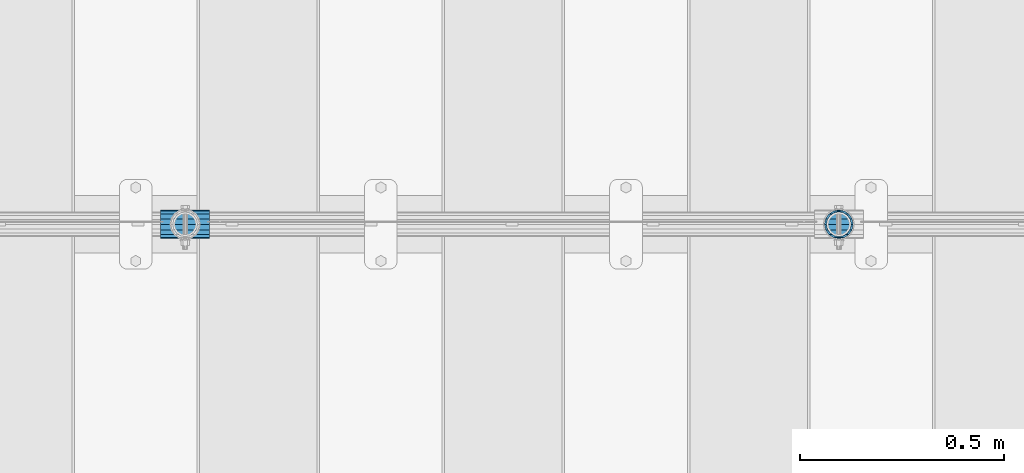
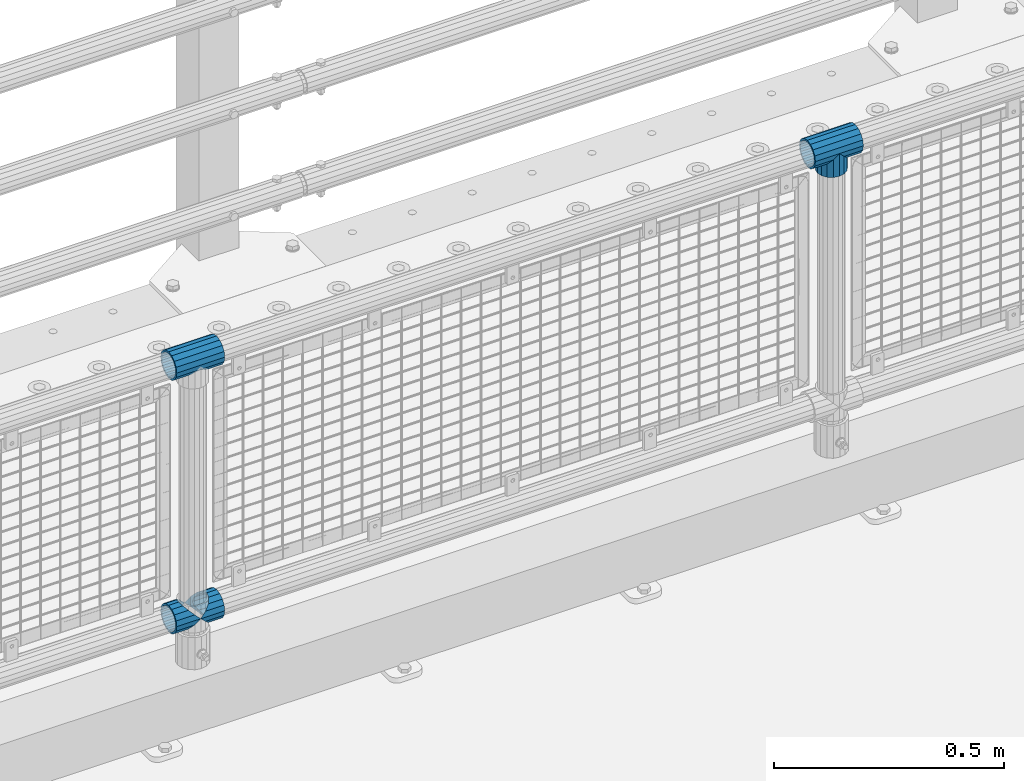
# One storey, part 155 of 257: 5 beams.
"""IFC2X3 building model written with IfcOpenShell, lengths in millimetres."""

from ifc_helpers import new_model, si_unit, frame, origin_with_axes, place, context, subcontext, project, spatial, faceted_brep, material, type_object, element, save


model = new_model("IFC2X3")

# Units and contexts
model_context = context("Model", 3, precision=1e-05, world=origin_with_axes())
body_context = subcontext(model_context, "Body", "Model", "MODEL_VIEW")
ifc_project = project(units=[si_unit("LENGTHUNIT", "METRE", prefix="MILLI"), si_unit("AREAUNIT", "SQUARE_METRE"), si_unit("VOLUMEUNIT", "CUBIC_METRE"), si_unit("MASSUNIT", "GRAM", prefix="KILO"), si_unit("TIMEUNIT", "SECOND"), si_unit("PLANEANGLEUNIT", "RADIAN"), si_unit("SOLIDANGLEUNIT", "STERADIAN"), si_unit("THERMODYNAMICTEMPERATUREUNIT", "DEGREE_CELSIUS"), si_unit("LUMINOUSINTENSITYUNIT", "LUMEN")], contexts=[model_context])

# Site, building, storey
site_placement = place(None, origin_with_axes())
site = spatial("IfcSite", under=ifc_project, at=site_placement, CompositionType="ELEMENT")
building_placement = place(site_placement, origin_with_axes())
building = spatial("IfcBuilding", under=site, at=building_placement, Name="Standard", CompositionType="ELEMENT")
storey_placement = place(building_placement, origin_with_axes())
storey = spatial("IfcBuildingStorey", under=building, at=storey_placement, Name="Undefined", CompositionType="ELEMENT", Elevation=0.0)

# Beams
ifc_material = material(Name="Misc_Undefined")
beam_type = type_object("IfcBeamType", PredefinedType="NOTDEFINED")
beam_1_placement = place(storey_placement, frame((52671.0, 10664.5, 969.849999999999), z_axis=(0.0, 1.0, 0.0), x_axis=(0.0, 0.0, -1.0)))
element("IfcBeam", 1, at=beam_1_placement, inside=storey, type_object=beam_type, material=ifc_material, context=body_context, shape_type="Brep", body=[
    faceted_brep([(0.0, 0.0, 35.1499999999996), (13.4513226476338, 13.4513226476329, 32.4743655677721), (13.4513226476338, -13.4513226476329, 32.4743655677721), (32.4743655677739, -32.4743655677717, -13.4513226476338), (32.4743655677739, -26.8123795176755, -13.4513226476338), (27.1226768591005, -21.4606908090117, -21.4606908090118), (24.8548033587067, -16.3810424080045, -24.8548033587067), (24.8548033587067, -24.8548033587072, -24.8548033587067), (13.4513226476338, -13.4513226476329, -32.4743655677721), (13.4513226476338, 13.4513226476329, -32.4743655677721), (0.0, 0.0, -35.1499999999996), (20.0882031229849, -11.6144421722805, -28.0397438117179), (16.6306603983685, 0.0, -30.3500000000004), (20.0882031229849, 11.6144421722805, -28.0397438117179), (24.8548033587067, 16.3810424080013, -24.8548033587067), (24.8548033587067, 24.8548033587072, -24.8548033587067), (32.4743655677739, 26.8123795176754, -13.4513226476338), (32.4743655677739, 32.4743655677717, -13.4513226476338), (27.1226768591005, 21.4606908090117, -21.4606908090118), (35.1500000000015, 30.35, 0.0), (35.1500000000015, 35.15, 0.0), (32.8397438117172, 28.0397438117175, -11.6144421722802), (32.8397438117172, 28.0397438117175, 11.6144421722802), (32.4743655677739, 26.8123795176755, 13.4513226476338), (32.4743655677739, 32.4743655677717, 13.4513226476338), (27.122676859115, 21.4606908090117, 21.4606908090118), (24.8548033587067, 16.3810424080013, 24.8548033587067), (24.8548033587067, 24.8548033587072, 24.8548033587067), (20.0882031229849, 11.6144421722805, 28.0397438117179), (16.6306603983758, 0.0, 30.3500000000004), (20.0882031229849, -11.6144421722805, 28.0397438117179), (24.8548033587067, -16.3810424080013, 24.8548033587067), (24.8548033587067, -24.8548033587072, 24.8548033587067), (27.122676859115, -21.4606908090117, 21.4606908090118), (32.4743655677739, -26.8123795176754, 13.4513226476338), (32.4743655677739, -32.4743655677717, 13.4513226476338), (32.8397438117172, -28.0397438117175, 11.6144421722802), (35.1500000000015, -30.35, 0.0), (35.1500000000015, -35.1499999999996, 0.0), (32.8397438117172, -28.0397438117175, -11.6144421722802), (60.1500000000015, -24.8548033587072, -24.8548033587067), (60.1500000000015, -32.4743655677717, -13.4513226476338), (60.1500000000015, -13.4513226476329, -32.4743655677721), (60.1500000000015, 0.0, -35.1499999999996), (60.1500000000015, 13.4513226476329, -32.4743655677721), (60.1500000000015, 24.8548033587072, -24.8548033587067), (60.1500000000015, 32.4743655677717, -13.4513226476338), (60.1500000000015, 35.15, 0.0), (60.1500000000015, 32.4743655677717, 13.4513226476338), (60.1500000000015, 24.8548033587072, 24.8548033587067), (60.1500000000015, 13.4513226476329, 32.4743655677721), (60.1500000000015, 0.0, 35.1499999999996), (60.1500000000015, -13.4513226476329, 32.4743655677721), (60.1500000000015, -24.8548033587072, 24.8548033587067), (60.1500000000015, -32.4743655677717, 13.4513226476338), (60.1500000000015, -35.15, 0.0), (60.1500000000015, -21.4606908090117, 21.4606908090118), (60.1500000000015, -11.6144421722805, 28.0397438117179), (60.1500000000015, 0.0, 30.3500000000004), (60.1500000000015, 11.6144421722805, 28.0397438117179), (60.1500000000015, 21.4606908090117, 21.4606908090118), (60.1500000000015, 28.0397438117175, 11.6144421722802), (60.1500000000015, 30.35, 0.0), (60.1500000000015, 28.0397438117175, -11.6144421722802), (60.1500000000015, 21.4606908090117, -21.4606908090118), (60.1500000000015, 11.6144421722805, -28.0397438117179), (60.1500000000015, 0.0, -30.3500000000004), (60.1500000000015, -11.6144421722805, -28.0397438117179), (60.1500000000015, -21.4606908090117, -21.4606908090118), (60.1500000000015, -28.0397438117175, -11.6144421722802), (60.1500000000015, -30.35, 0.0), (60.1500000000015, -28.0397438117175, 11.6144421722802)], [[[0, 1, 2]], [[3, 4, 5, 6, 7]], [[8, 9, 10]], [[7, 6, 11, 12, 13, 14, 15, 9, 8]], [[16, 17, 15, 14, 18]], [[19, 20, 17, 16, 21]], [[22, 23, 24, 20, 19]], [[25, 26, 27, 24, 23]], [[2, 1, 27, 26, 28, 29, 30, 31, 32]], [[32, 31, 33, 34, 35]], [[35, 34, 36, 37, 38]], [[38, 37, 39, 4, 3]], [[40, 41, 3, 7]], [[42, 40, 7, 8]], [[43, 42, 8, 10]], [[44, 43, 10, 9]], [[45, 44, 9, 15]], [[46, 45, 15, 17]], [[47, 46, 17, 20]], [[48, 47, 20, 24]], [[49, 48, 24, 27]], [[50, 49, 27, 1]], [[51, 50, 1, 0]], [[52, 51, 0, 2]], [[53, 52, 2, 32]], [[54, 53, 32, 35]], [[55, 54, 35, 38]], [[41, 55, 38, 3]], [[40, 42, 43, 44, 45, 46, 47, 48, 49, 50, 51, 52, 53, 54, 55, 41], [56, 57, 58, 59, 60, 61, 62, 63, 64, 65, 66, 67, 68, 69, 70, 71]], [[71, 70, 37, 36]], [[33, 56, 71, 36, 34]], [[30, 57, 56, 33, 31]], [[58, 57, 30, 29]], [[59, 58, 29, 28]], [[60, 59, 28, 26, 25]], [[61, 60, 25, 23, 22]], [[62, 61, 22, 19]], [[63, 62, 19, 21]], [[18, 64, 63, 21, 16]], [[13, 65, 64, 18, 14]], [[66, 65, 13, 12]], [[67, 66, 12, 11]], [[68, 67, 11, 6, 5]], [[69, 68, 5, 4, 39]], [[70, 69, 39, 37]]]),
])
beam_2_placement = place(storey_placement, frame((52610.85, 10664.5, 969.849999999999), z_axis=(0.0, 0.0, 1.0), x_axis=(1.0, 0.0, 0.0)))
element("IfcBeam", 2, at=beam_2_placement, inside=storey, type_object=beam_type, material=ifc_material, context=body_context, shape_type="Brep", body=[
    faceted_brep([(88.1897438117157, -11.6144421722802, -28.0397438117176), (88.1897438117157, -11.6144421722802, -32.8397438117175), (86.962379517674, -13.4513226476338, -32.4743655677718), (81.6106908090151, -21.4606908090118, -27.122676859108), (81.6106908090151, -21.4606908090118, -21.4606908090117), (76.5310424080017, -24.8548033587067, -24.8548033587072), (71.7644421722798, -28.0397438117179, -20.0882031229829), (71.7644421722798, -28.0397438117179, -11.6144421722805), (60.1500000000015, -30.3500000000004, -16.6306603983671), (60.1500000000015, -30.35, 0.0), (48.5355578277231, -28.0397438117179, -20.0882031229829), (48.5355578277231, -28.0397438117179, -11.6144421722805), (43.7689575920012, -24.8548033587067, -24.8548033587072), (38.6893091909878, -21.4606908090118, -27.122676859108), (38.6893091909878, -21.4606908090118, -21.4606908090117), (33.3376204823144, -13.4513226476338, -32.4743655677718), (32.1102561882872, -11.6144421722802, -32.8397438117175), (32.1102561882872, -11.6144421722802, -28.0397438117176), (29.8000000000029, 0.0, -35.15), (29.8000000000029, 0.0, -30.35), (32.1102561882872, 11.6144421722802, -32.8397438117178), (32.1102561882872, 11.6144421722802, -28.0397438117176), (33.3376204823289, 13.4513226476338, -32.4743655677718), (38.6893091909878, 21.4606908090118, -27.1226768591091), (38.6893091909878, 21.4606908090118, -21.4606908090117), (43.7689575920012, 24.8548033587067, -24.8548033587072), (48.5355578277231, 28.0397438117179, -20.0882031229829), (48.5355578277231, 28.0397438117179, -11.6144421722805), (60.1500000000015, 30.3500000000004, -16.6306603983671), (60.1500000000015, 30.35, 0.0), (71.7644421722798, 28.0397438117179, -20.0882031229829), (71.7644421722798, 28.0397438117179, -11.6144421722805), (76.5310424080017, 24.8548033587067, -24.8548033587072), (81.6106908090151, 21.4606908090118, -27.1226768591091), (81.6106908090151, 21.4606908090118, -21.4606908090117), (86.9623795176813, 13.4513226476338, -32.4743655677718), (88.1897438117157, 11.6144421722802, -32.8397438117178), (88.1897438117157, 11.6144421722802, -28.0397438117176), (90.5, 0.0, -35.15), (90.5, 0.0, -30.35), (0.0, -21.4606908090118, -21.4606908090136), (0.0, -28.0397438117179, -11.6144421722784), (0.0, -11.6144421722802, -28.0397438117143), (0.0, 0.0, -30.3499999999985), (0.0, 11.6144421722802, -28.0397438117143), (0.0, 21.4606908090118, -21.4606908090136), (0.0, 28.0397438117179, -11.6144421722784), (0.0, 30.3500000000004, 0.0), (0.0, 32.4743655677721, -13.4513226476338), (0.0, 35.1499999999996, 0.0), (120.300000000003, 35.1499999999996, 0.0), (120.300000000003, 32.4743655677721, -13.4513226476329), (0.0, 32.4743655677721, 13.4513226476338), (120.300000000003, 32.4743655677721, 13.4513226476329), (0.0, 24.8548033587067, 24.8548033587067), (120.300000000003, 24.8548033587067, 24.8548033587072), (0.0, 13.4513226476338, 32.4743655677739), (120.300000000003, 13.4513226476338, 32.4743655677718), (0.0, 0.0, 35.1499999999996), (120.300000000003, 0.0, 35.15), (0.0, -13.4513226476338, 32.4743655677739), (120.300000000003, -13.4513226476338, 32.4743655677718), (0.0, -24.8548033587067, 24.8548033587067), (120.300000000003, -24.8548033587067, 24.8548033587072), (0.0, -32.4743655677721, 13.4513226476338), (120.300000000003, -32.4743655677721, 13.4513226476329), (0.0, -35.1499999999996, 0.0), (120.300000000003, -35.1499999999996, 0.0), (0.0, -32.4743655677721, -13.4513226476338), (120.300000000003, -32.4743655677721, -13.4513226476329), (0.0, 24.8548033587067, -24.8548033587067), (0.0, 13.4513226476338, -32.4743655677739), (0.0, 0.0, -35.1499999999996), (0.0, -13.4513226476338, -32.4743655677739), (0.0, -24.8548033587067, -24.8548033587067), (0.0, 28.0397438117179, 11.6144421722784), (0.0, 21.4606908090118, 21.4606908090136), (0.0, 11.6144421722802, 28.0397438117143), (0.0, 0.0, 30.3499999999985), (0.0, -11.6144421722802, 28.0397438117143), (0.0, -21.4606908090118, 21.4606908090136), (0.0, -28.0397438117179, 11.6144421722784), (0.0, -30.3500000000004, 0.0), (120.300000000003, -30.3500000000004, 0.0), (120.300000000003, -28.0397438117179, -11.6144421722805), (120.300000000003, -21.4606908090118, -21.4606908090117), (120.300000000003, -11.6144421722802, -28.0397438117176), (120.300000000003, 0.0, -30.35), (120.300000000003, 21.4606908090118, -21.4606908090117), (120.300000000003, 28.0397438117179, -11.6144421722805), (120.300000000003, 11.6144421722802, -28.0397438117176), (120.300000000003, 30.3500000000004, 0.0), (120.300000000003, 28.0397438117179, 11.6144421722805), (120.300000000003, 21.4606908090118, 21.4606908090117), (120.300000000003, 11.6144421722802, 28.0397438117176), (120.300000000003, 0.0, 30.35), (120.300000000003, -11.6144421722802, 28.0397438117176), (120.300000000003, -21.4606908090118, 21.4606908090117), (120.300000000003, -28.0397438117179, 11.6144421722805), (120.300000000003, -24.8548033587067, -24.8548033587072), (120.300000000003, -13.4513226476338, -32.4743655677718), (120.300000000003, 0.0, -35.15), (120.300000000003, 13.4513226476338, -32.4743655677718), (120.300000000003, 24.8548033587067, -24.8548033587072)], [[[0, 1, 2, 3, 4]], [[4, 3, 5, 6, 7]], [[7, 6, 8, 9]], [[9, 8, 10, 11]], [[11, 10, 12, 13, 14]], [[14, 13, 15, 16, 17]], [[17, 16, 18, 19]], [[19, 18, 20, 21]], [[21, 20, 22, 23, 24]], [[24, 23, 25, 26, 27]], [[27, 26, 28, 29]], [[29, 28, 30, 31]], [[31, 30, 32, 33, 34]], [[34, 33, 35, 36, 37]], [[37, 36, 38, 39]], [[39, 38, 1, 0]], [[40, 41, 11, 14]], [[42, 40, 14, 17]], [[43, 42, 17, 19]], [[44, 43, 19, 21]], [[45, 44, 21, 24]], [[46, 45, 24, 27]], [[47, 46, 27, 29]], [[48, 49, 50, 51]], [[49, 52, 53, 50]], [[52, 54, 55, 53]], [[54, 56, 57, 55]], [[56, 58, 59, 57]], [[58, 60, 61, 59]], [[60, 62, 63, 61]], [[62, 64, 65, 63]], [[64, 66, 67, 65]], [[66, 68, 69, 67]], [[64, 62, 60, 58, 56, 54, 52, 49, 48, 70, 71, 72, 73, 74, 68, 66], [41, 40, 42, 43, 44, 45, 46, 47, 75, 76, 77, 78, 79, 80, 81, 82]], [[41, 82, 9, 11]], [[83, 84, 7, 9]], [[84, 85, 4, 7]], [[85, 86, 0, 4]], [[86, 87, 39, 0]], [[88, 89, 31, 34]], [[90, 88, 34, 37]], [[87, 90, 37, 39]], [[89, 91, 29, 31]], [[75, 47, 29, 91, 92]], [[76, 75, 92, 93]], [[77, 76, 93, 94]], [[78, 77, 94, 95]], [[79, 78, 95, 96]], [[80, 79, 96, 97]], [[81, 80, 97, 98]], [[9, 82, 81, 98, 83]], [[99, 100, 101, 102, 103, 51, 50, 53, 55, 57, 59, 61, 63, 65, 67, 69], [97, 96, 95, 94, 93, 92, 91, 89, 88, 90, 87, 86, 85, 84, 83, 98]], [[35, 102, 101, 38, 36]], [[32, 103, 102, 35, 33]], [[28, 26, 25, 70, 48, 51, 103, 32, 30]], [[22, 71, 70, 25, 23]], [[18, 72, 71, 22, 20]], [[73, 72, 18, 16, 15]], [[74, 73, 15, 13, 12]], [[99, 69, 68, 74, 12, 10, 8, 6, 5]], [[100, 99, 5, 3, 2]], [[101, 100, 2, 1, 38]]]),
])
beam_3_placement = place(storey_placement, frame((51010.85, 10664.5, 969.849999999999), z_axis=(0.0, 0.0, 1.0), x_axis=(1.0, 0.0, 0.0)))
element("IfcBeam", 3, at=beam_3_placement, inside=storey, type_object=beam_type, material=ifc_material, context=body_context, shape_type="Brep", body=[
    faceted_brep([(88.1897438117157, -11.6144421722802, -28.0397438117176), (88.1897438117157, -11.6144421722802, -32.8397438117175), (86.962379517674, -13.4513226476338, -32.4743655677718), (81.6106908090151, -21.4606908090118, -27.122676859108), (81.6106908090151, -21.4606908090118, -21.4606908090117), (76.5310424080017, -24.8548033587067, -24.8548033587072), (71.7644421722798, -28.0397438117179, -20.0882031229829), (71.7644421722798, -28.0397438117179, -11.6144421722805), (60.1500000000015, -30.3500000000004, -16.6306603983671), (60.1500000000015, -30.35, 0.0), (48.5355578277231, -28.0397438117179, -20.0882031229829), (48.5355578277231, -28.0397438117179, -11.6144421722805), (43.7689575920012, -24.8548033587067, -24.8548033587072), (38.6893091909878, -21.4606908090118, -27.122676859108), (38.6893091909878, -21.4606908090118, -21.4606908090117), (33.3376204823144, -13.4513226476338, -32.4743655677718), (32.1102561882872, -11.6144421722802, -32.8397438117175), (32.1102561882872, -11.6144421722802, -28.0397438117176), (29.8000000000029, 0.0, -35.15), (29.8000000000029, 0.0, -30.35), (32.1102561882872, 11.6144421722802, -32.8397438117178), (32.1102561882872, 11.6144421722802, -28.0397438117176), (33.3376204823289, 13.4513226476338, -32.4743655677718), (38.6893091909878, 21.4606908090118, -27.1226768591091), (38.6893091909878, 21.4606908090118, -21.4606908090117), (43.7689575920012, 24.8548033587067, -24.8548033587072), (48.5355578277231, 28.0397438117179, -20.0882031229829), (48.5355578277231, 28.0397438117179, -11.6144421722805), (60.1500000000015, 30.3500000000004, -16.6306603983671), (60.1500000000015, 30.35, 0.0), (71.7644421722798, 28.0397438117179, -20.0882031229829), (71.7644421722798, 28.0397438117179, -11.6144421722805), (76.5310424080017, 24.8548033587067, -24.8548033587072), (81.6106908090151, 21.4606908090118, -27.1226768591091), (81.6106908090151, 21.4606908090118, -21.4606908090117), (86.9623795176813, 13.4513226476338, -32.4743655677718), (88.1897438117157, 11.6144421722802, -32.8397438117178), (88.1897438117157, 11.6144421722802, -28.0397438117176), (90.5, 0.0, -35.15), (90.5, 0.0, -30.35), (0.0, -21.4606908090118, -21.4606908090136), (0.0, -28.0397438117179, -11.6144421722784), (0.0, -11.6144421722802, -28.0397438117143), (0.0, 0.0, -30.3499999999985), (0.0, 11.6144421722802, -28.0397438117143), (0.0, 21.4606908090118, -21.4606908090136), (0.0, 28.0397438117179, -11.6144421722784), (0.0, 30.3500000000004, 0.0), (0.0, 32.4743655677721, -13.4513226476338), (0.0, 35.1499999999996, 0.0), (120.300000000003, 35.1499999999996, 0.0), (120.300000000003, 32.4743655677721, -13.4513226476329), (0.0, 32.4743655677721, 13.4513226476338), (120.300000000003, 32.4743655677721, 13.4513226476329), (0.0, 24.8548033587067, 24.8548033587067), (120.300000000003, 24.8548033587067, 24.8548033587072), (0.0, 13.4513226476338, 32.4743655677739), (120.300000000003, 13.4513226476338, 32.4743655677718), (0.0, 0.0, 35.1499999999996), (120.300000000003, 0.0, 35.15), (0.0, -13.4513226476338, 32.4743655677739), (120.300000000003, -13.4513226476338, 32.4743655677718), (0.0, -24.8548033587067, 24.8548033587067), (120.300000000003, -24.8548033587067, 24.8548033587072), (0.0, -32.4743655677721, 13.4513226476338), (120.300000000003, -32.4743655677721, 13.4513226476329), (0.0, -35.1499999999996, 0.0), (120.300000000003, -35.1499999999996, 0.0), (0.0, -32.4743655677721, -13.4513226476338), (120.300000000003, -32.4743655677721, -13.4513226476329), (0.0, 24.8548033587067, -24.8548033587067), (0.0, 13.4513226476338, -32.4743655677739), (0.0, 0.0, -35.1499999999996), (0.0, -13.4513226476338, -32.4743655677739), (0.0, -24.8548033587067, -24.8548033587067), (0.0, 28.0397438117179, 11.6144421722784), (0.0, 21.4606908090118, 21.4606908090136), (0.0, 11.6144421722802, 28.0397438117143), (0.0, 0.0, 30.3499999999985), (0.0, -11.6144421722802, 28.0397438117143), (0.0, -21.4606908090118, 21.4606908090136), (0.0, -28.0397438117179, 11.6144421722784), (0.0, -30.3500000000004, 0.0), (120.300000000003, -30.3500000000004, 0.0), (120.300000000003, -28.0397438117179, -11.6144421722805), (120.300000000003, -21.4606908090118, -21.4606908090117), (120.300000000003, -11.6144421722802, -28.0397438117176), (120.300000000003, 0.0, -30.35), (120.300000000003, 21.4606908090118, -21.4606908090117), (120.300000000003, 28.0397438117179, -11.6144421722805), (120.300000000003, 11.6144421722802, -28.0397438117176), (120.300000000003, 30.3500000000004, 0.0), (120.300000000003, 28.0397438117179, 11.6144421722805), (120.300000000003, 21.4606908090118, 21.4606908090117), (120.300000000003, 11.6144421722802, 28.0397438117176), (120.300000000003, 0.0, 30.35), (120.300000000003, -11.6144421722802, 28.0397438117176), (120.300000000003, -21.4606908090118, 21.4606908090117), (120.300000000003, -28.0397438117179, 11.6144421722805), (120.300000000003, -24.8548033587067, -24.8548033587072), (120.300000000003, -13.4513226476338, -32.4743655677718), (120.300000000003, 0.0, -35.15), (120.300000000003, 13.4513226476338, -32.4743655677718), (120.300000000003, 24.8548033587067, -24.8548033587072)], [[[0, 1, 2, 3, 4]], [[4, 3, 5, 6, 7]], [[7, 6, 8, 9]], [[9, 8, 10, 11]], [[11, 10, 12, 13, 14]], [[14, 13, 15, 16, 17]], [[17, 16, 18, 19]], [[19, 18, 20, 21]], [[21, 20, 22, 23, 24]], [[24, 23, 25, 26, 27]], [[27, 26, 28, 29]], [[29, 28, 30, 31]], [[31, 30, 32, 33, 34]], [[34, 33, 35, 36, 37]], [[37, 36, 38, 39]], [[39, 38, 1, 0]], [[40, 41, 11, 14]], [[42, 40, 14, 17]], [[43, 42, 17, 19]], [[44, 43, 19, 21]], [[45, 44, 21, 24]], [[46, 45, 24, 27]], [[47, 46, 27, 29]], [[48, 49, 50, 51]], [[49, 52, 53, 50]], [[52, 54, 55, 53]], [[54, 56, 57, 55]], [[56, 58, 59, 57]], [[58, 60, 61, 59]], [[60, 62, 63, 61]], [[62, 64, 65, 63]], [[64, 66, 67, 65]], [[66, 68, 69, 67]], [[64, 62, 60, 58, 56, 54, 52, 49, 48, 70, 71, 72, 73, 74, 68, 66], [41, 40, 42, 43, 44, 45, 46, 47, 75, 76, 77, 78, 79, 80, 81, 82]], [[41, 82, 9, 11]], [[83, 84, 7, 9]], [[84, 85, 4, 7]], [[85, 86, 0, 4]], [[86, 87, 39, 0]], [[88, 89, 31, 34]], [[90, 88, 34, 37]], [[87, 90, 37, 39]], [[89, 91, 29, 31]], [[75, 47, 29, 91, 92]], [[76, 75, 92, 93]], [[77, 76, 93, 94]], [[78, 77, 94, 95]], [[79, 78, 95, 96]], [[80, 79, 96, 97]], [[81, 80, 97, 98]], [[9, 82, 81, 98, 83]], [[99, 100, 101, 102, 103, 51, 50, 53, 55, 57, 59, 61, 63, 65, 67, 69], [97, 96, 95, 94, 93, 92, 91, 89, 88, 90, 87, 86, 85, 84, 83, 98]], [[35, 102, 101, 38, 36]], [[32, 103, 102, 35, 33]], [[28, 26, 25, 70, 48, 51, 103, 32, 30]], [[22, 71, 70, 25, 23]], [[18, 72, 71, 22, 20]], [[73, 72, 18, 16, 15]], [[74, 73, 15, 13, 12]], [[99, 69, 68, 74, 12, 10, 8, 6, 5]], [[100, 99, 5, 3, 2]], [[101, 100, 2, 1, 38]]]),
])
beam_4_placement = place(storey_placement, frame((51010.85, 10664.5, 298.17), z_axis=(0.0, 1.0, 0.0), x_axis=(1.0, 0.0, 0.0)))
element("IfcBeam", 4, at=beam_4_placement, inside=storey, type_object=beam_type, material=ifc_material, context=body_context, shape_type="Brep", body=[
    faceted_brep([(60.1500000000015, 0.0, -35.1499999999996), (46.6986773523677, 13.4513226476329, -32.4743655677721), (46.6986773523677, -13.4513226476329, -32.4743655677721), (33.0273231408937, 21.4606908090117, 21.4606908090118), (27.6756344322275, 26.8123795176764, 13.4513226476338), (27.6756344322275, 32.4743655677717, 13.4513226476338), (35.2951966412948, 24.8548033587072, 24.8548033587067), (35.2951966412948, 16.3810424080013, 24.8548033587067), (27.3102561882843, 28.0397438117175, 11.6144421722802), (25.0, 30.35, 0.0), (25.0, 35.15, 0.0), (27.6756344322275, 26.8123795176754, -13.4513226476338), (27.6756344322275, 32.4743655677717, -13.4513226476338), (27.3102561882843, 28.0397438117175, -11.6144421722802), (35.2951966412948, 16.3810424080013, -24.8548033587067), (35.2951966412948, 24.8548033587072, -24.8548033587067), (33.0273231408864, 21.4606908090117, -21.4606908090118), (40.0617968770239, 11.6144421722805, -28.0397438117179), (43.5193396016475, 0.0, -30.3500000000004), (40.0617968770239, -11.6144421722805, -28.0397438117179), (35.2951966412948, -16.3810424080078, -24.8548033587067), (35.2951966412948, -24.8548033587072, -24.8548033587067), (33.0273231408864, -21.4606908090117, -21.4606908090118), (27.6756344322275, -26.8123795176764, -13.4513226476338), (27.6756344322275, -32.4743655677717, -13.4513226476338), (27.3102561882843, -28.0397438117175, -11.6144421722802), (25.0, -30.35, 0.0), (25.0, -35.15, 0.0), (27.3102561882843, -28.0397438117175, 11.6144421722802), (27.6756344322275, -26.8123795176754, 13.4513226476338), (27.6756344322275, -32.4743655677717, 13.4513226476338), (33.0273231408937, -21.4606908090117, 21.4606908090118), (35.2951966412948, -16.3810424080045, 24.8548033587067), (35.2951966412948, -24.8548033587072, 24.8548033587067), (60.1500000000015, 0.0, 35.1499999999996), (46.6986773523677, -13.4513226476329, 32.4743655677721), (46.6986773523677, 13.4513226476329, 32.4743655677721), (40.0617968770166, -11.6144421722805, 28.0397438117179), (43.519339601633, 0.0, 30.3500000000004), (40.0617968770166, 11.6144421722805, 28.0397438117179), (0.0, -32.4743655677721, -13.4513226476338), (0.0, -24.8548033587067, -24.8548033587067), (0.0, -13.4513226476338, -32.4743655677739), (0.0, 0.0, -35.1499999999996), (0.0, 13.4513226476338, -32.4743655677739), (0.0, 24.8548033587067, -24.8548033587067), (0.0, 32.4743655677721, -13.4513226476338), (0.0, 35.1499999999996, 0.0), (0.0, 32.4743655677721, 13.4513226476338), (0.0, 24.8548033587067, 24.8548033587067), (0.0, 13.4513226476338, 32.4743655677739), (0.0, 0.0, 35.1499999999996), (0.0, -32.4743655677721, 13.4513226476338), (0.0, -35.1499999999996, 0.0), (0.0, -24.8548033587067, 24.8548033587067), (0.0, -13.4513226476338, 32.4743655677739), (0.0, -28.0397438117179, -11.6144421722784), (0.0, -21.4606908090118, -21.4606908090136), (0.0, -11.6144421722802, -28.0397438117143), (0.0, 0.0, -30.3499999999985), (0.0, 11.6144421722802, -28.0397438117143), (0.0, 21.4606908090118, -21.4606908090136), (0.0, 28.0397438117179, -11.6144421722784), (0.0, 30.3500000000004, 0.0), (0.0, 28.0397438117179, 11.6144421722784), (0.0, 21.4606908090118, 21.4606908090136), (0.0, 11.6144421722802, 28.0397438117143), (0.0, 0.0, 30.3499999999985), (0.0, -11.6144421722802, 28.0397438117143), (0.0, -21.4606908090118, 21.4606908090136), (0.0, -28.0397438117179, 11.6144421722784), (0.0, -30.3500000000004, 0.0)], [[[0, 1, 2]], [[3, 4, 5, 6, 7]], [[8, 9, 10, 5, 4]], [[11, 12, 10, 9, 13]], [[14, 15, 12, 11, 16]], [[2, 1, 15, 14, 17, 18, 19, 20, 21]], [[21, 20, 22, 23, 24]], [[24, 23, 25, 26, 27]], [[27, 26, 28, 29, 30]], [[30, 29, 31, 32, 33]], [[34, 35, 36]], [[33, 32, 37, 38, 39, 7, 6, 36, 35]], [[40, 41, 21, 24]], [[41, 42, 2, 21]], [[42, 43, 0, 2]], [[43, 44, 1, 0]], [[44, 45, 15, 1]], [[45, 46, 12, 15]], [[46, 47, 10, 12]], [[47, 48, 5, 10]], [[48, 49, 6, 5]], [[49, 50, 36, 6]], [[50, 51, 34, 36]], [[52, 53, 27, 30]], [[54, 52, 30, 33]], [[55, 54, 33, 35]], [[51, 55, 35, 34]], [[53, 40, 24, 27]], [[52, 54, 55, 51, 50, 49, 48, 47, 46, 45, 44, 43, 42, 41, 40, 53], [56, 57, 58, 59, 60, 61, 62, 63, 64, 65, 66, 67, 68, 69, 70, 71]], [[68, 67, 38, 37]], [[31, 69, 68, 37, 32]], [[28, 70, 69, 31, 29]], [[71, 70, 28, 26]], [[56, 71, 26, 25]], [[57, 56, 25, 23, 22]], [[58, 57, 22, 20, 19]], [[59, 58, 19, 18]], [[60, 59, 18, 17]], [[16, 61, 60, 17, 14]], [[13, 62, 61, 16, 11]], [[63, 62, 13, 9]], [[64, 63, 9, 8]], [[65, 64, 8, 4, 3]], [[66, 65, 3, 7, 39]], [[67, 66, 39, 38]]]),
])
beam_5_placement = place(storey_placement, frame((51071.0, 10664.5, 298.17), z_axis=(0.0, 1.0, 0.0), x_axis=(1.0, 0.0, 0.0)))
element("IfcBeam", 5, at=beam_5_placement, inside=storey, type_object=beam_type, material=ifc_material, context=body_context, shape_type="Brep", body=[
    faceted_brep([(0.0, 0.0, 35.1499999999996), (13.4513226476338, 13.4513226476329, 32.4743655677721), (13.4513226476338, -13.4513226476329, 32.4743655677721), (32.4743655677739, -32.4743655677717, -13.4513226476338), (32.4743655677739, -26.8123795176755, -13.4513226476338), (27.1226768591005, -21.4606908090117, -21.4606908090118), (24.8548033587067, -16.3810424080045, -24.8548033587067), (24.8548033587067, -24.8548033587072, -24.8548033587067), (13.4513226476338, -13.4513226476329, -32.4743655677721), (13.4513226476338, 13.4513226476329, -32.4743655677721), (0.0, 0.0, -35.1499999999996), (20.0882031229849, -11.6144421722805, -28.0397438117179), (16.6306603983685, 0.0, -30.3500000000004), (20.0882031229849, 11.6144421722805, -28.0397438117179), (24.8548033587067, 16.3810424080013, -24.8548033587067), (24.8548033587067, 24.8548033587072, -24.8548033587067), (32.4743655677739, 26.8123795176754, -13.4513226476338), (32.4743655677739, 32.4743655677717, -13.4513226476338), (27.1226768591005, 21.4606908090117, -21.4606908090118), (35.1500000000015, 30.35, 0.0), (35.1500000000015, 35.15, 0.0), (32.8397438117172, 28.0397438117175, -11.6144421722802), (32.8397438117172, 28.0397438117175, 11.6144421722802), (32.4743655677739, 26.8123795176755, 13.4513226476338), (32.4743655677739, 32.4743655677717, 13.4513226476338), (27.122676859115, 21.4606908090117, 21.4606908090118), (24.8548033587067, 16.3810424080013, 24.8548033587067), (24.8548033587067, 24.8548033587072, 24.8548033587067), (20.0882031229849, 11.6144421722805, 28.0397438117179), (16.6306603983758, 0.0, 30.3500000000004), (20.0882031229849, -11.6144421722805, 28.0397438117179), (24.8548033587067, -16.3810424080013, 24.8548033587067), (24.8548033587067, -24.8548033587072, 24.8548033587067), (27.122676859115, -21.4606908090117, 21.4606908090118), (32.4743655677739, -26.8123795176754, 13.4513226476338), (32.4743655677739, -32.4743655677717, 13.4513226476338), (32.8397438117172, -28.0397438117175, 11.6144421722802), (35.1500000000015, -30.35, 0.0), (35.1500000000015, -35.1499999999996, 0.0), (32.8397438117172, -28.0397438117175, -11.6144421722802), (60.1500000000015, -24.8548033587072, -24.8548033587067), (60.1500000000015, -32.4743655677717, -13.4513226476338), (60.1500000000015, -13.4513226476329, -32.4743655677721), (60.1500000000015, 0.0, -35.1499999999996), (60.1500000000015, 13.4513226476329, -32.4743655677721), (60.1500000000015, 24.8548033587072, -24.8548033587067), (60.1500000000015, 32.4743655677717, -13.4513226476338), (60.1500000000015, 35.15, 0.0), (60.1500000000015, 32.4743655677717, 13.4513226476338), (60.1500000000015, 24.8548033587072, 24.8548033587067), (60.1500000000015, 13.4513226476329, 32.4743655677721), (60.1500000000015, 0.0, 35.1499999999996), (60.1500000000015, -13.4513226476329, 32.4743655677721), (60.1500000000015, -24.8548033587072, 24.8548033587067), (60.1500000000015, -32.4743655677717, 13.4513226476338), (60.1500000000015, -35.15, 0.0), (60.1500000000015, -21.4606908090117, 21.4606908090118), (60.1500000000015, -11.6144421722805, 28.0397438117179), (60.1500000000015, 0.0, 30.3500000000004), (60.1500000000015, 11.6144421722805, 28.0397438117179), (60.1500000000015, 21.4606908090117, 21.4606908090118), (60.1500000000015, 28.0397438117175, 11.6144421722802), (60.1500000000015, 30.35, 0.0), (60.1500000000015, 28.0397438117175, -11.6144421722802), (60.1500000000015, 21.4606908090117, -21.4606908090118), (60.1500000000015, 11.6144421722805, -28.0397438117179), (60.1500000000015, 0.0, -30.3500000000004), (60.1500000000015, -11.6144421722805, -28.0397438117179), (60.1500000000015, -21.4606908090117, -21.4606908090118), (60.1500000000015, -28.0397438117175, -11.6144421722802), (60.1500000000015, -30.35, 0.0), (60.1500000000015, -28.0397438117175, 11.6144421722802)], [[[0, 1, 2]], [[3, 4, 5, 6, 7]], [[8, 9, 10]], [[7, 6, 11, 12, 13, 14, 15, 9, 8]], [[16, 17, 15, 14, 18]], [[19, 20, 17, 16, 21]], [[22, 23, 24, 20, 19]], [[25, 26, 27, 24, 23]], [[2, 1, 27, 26, 28, 29, 30, 31, 32]], [[32, 31, 33, 34, 35]], [[35, 34, 36, 37, 38]], [[38, 37, 39, 4, 3]], [[40, 41, 3, 7]], [[42, 40, 7, 8]], [[43, 42, 8, 10]], [[44, 43, 10, 9]], [[45, 44, 9, 15]], [[46, 45, 15, 17]], [[47, 46, 17, 20]], [[48, 47, 20, 24]], [[49, 48, 24, 27]], [[50, 49, 27, 1]], [[51, 50, 1, 0]], [[52, 51, 0, 2]], [[53, 52, 2, 32]], [[54, 53, 32, 35]], [[55, 54, 35, 38]], [[41, 55, 38, 3]], [[40, 42, 43, 44, 45, 46, 47, 48, 49, 50, 51, 52, 53, 54, 55, 41], [56, 57, 58, 59, 60, 61, 62, 63, 64, 65, 66, 67, 68, 69, 70, 71]], [[71, 70, 37, 36]], [[33, 56, 71, 36, 34]], [[30, 57, 56, 33, 31]], [[58, 57, 30, 29]], [[59, 58, 29, 28]], [[60, 59, 28, 26, 25]], [[61, 60, 25, 23, 22]], [[62, 61, 22, 19]], [[63, 62, 19, 21]], [[18, 64, 63, 21, 16]], [[13, 65, 64, 18, 14]], [[66, 65, 13, 12]], [[67, 66, 12, 11]], [[68, 67, 11, 6, 5]], [[69, 68, 5, 4, 39]], [[70, 69, 39, 37]]]),
])

save(model, "model.ifc")
